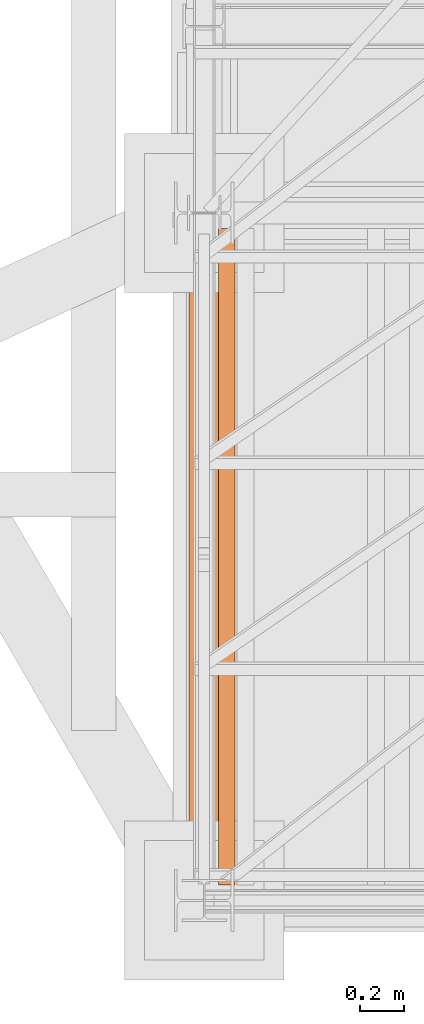
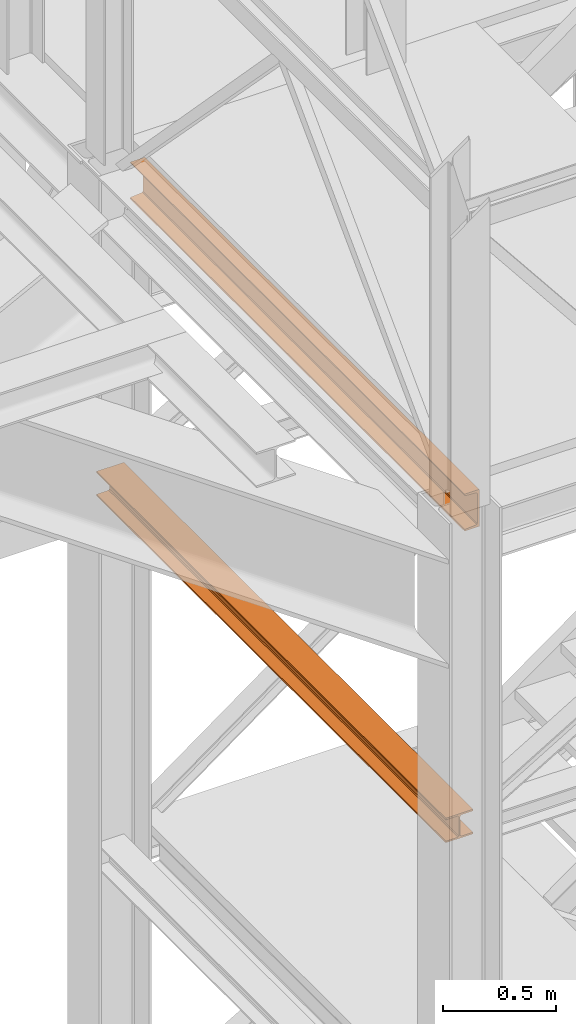
# One storey, part 4 of 208: 2 proxies.
"""IFC2X3 building model written with IfcOpenShell, lengths in millimetres."""

from ifc_helpers import new_model, entity, si_unit, converted_unit, frame, origin, origin_with_axes, place, context, subcontext, project, spatial, faceted_brep, element, save


model = new_model("IFC2X3")

# Units and contexts
model_context = context("Model", 3, precision=1e-05, world=origin())
plan_context = context("Plan", 3, precision=1e-05, world=origin())
body_context = subcontext(model_context, "Body", "Model", "MODEL_VIEW")
ifc_project = project(units=[si_unit("LENGTHUNIT", "METRE", prefix="MILLI"), converted_unit("PLANEANGLEUNIT", "DEGREE", entity("IfcPlaneAngleMeasure", 0.0174532925199433), si_unit("PLANEANGLEUNIT", "RADIAN"), dimensions=[0, 0, 0, 0, 0, 0, 0]), si_unit("AREAUNIT", "SQUARE_METRE"), si_unit("VOLUMEUNIT", "CUBIC_METRE")], contexts=[model_context, plan_context])

# Building, storey
building_placement = place(None, origin())
building = spatial("IfcBuilding", under=ifc_project, at=building_placement, CompositionType="COMPLEX")
storey_placement = place(building_placement, origin_with_axes())
storey = spatial("IfcBuildingStorey", under=building, at=storey_placement, Name="Geschoss", CompositionType="ELEMENT")

# Proxies
proxy_1_placement = place(storey_placement, frame((1128.922936086901, -25168.5743901279, 3447.489998909947), z_axis=(0.0, 0.0, 1.0), x_axis=(1.0, 0.0, 0.0)))
element("IfcBuildingElementProxy", 1, at=proxy_1_placement, inside=storey, context=body_context, shape_type="Brep", body=[
    faceted_brep([(0.01000000000067303, 3102.009999620019, 8.510002324581365), (0.01000000000067303, 3102.009999620019, 0.01000000000021828), (140.0100005960469, 3102.009999620019, 0.01000000000021828), (140.0100005960469, 3102.009999620019, 8.510002324581365), (84.76000038743086, 3102.009999620019, 8.510002324581365), (78.54945996612378, 3102.009999620019, 9.753034839630345), (74.00303279817172, 3102.009999620019, 14.29946480155013), (72.76000051595338, 3102.009999620019, 20.51000429153464), (72.76000051595338, 3102.009999620019, 112.5100007450583), (74.00303279817172, 3102.009999620019, 118.7205402350428), (78.54945996612378, 3102.009999620019, 123.2669664716723), (84.76000038743086, 3102.009999620019, 124.5099989867213), (140.0100005960469, 3102.009999620019, 124.5099989867213), (140.0100005960469, 3102.009999620019, 133.0100013113024), (0.01000000000067303, 3102.009999620019, 133.0100013113024), (0.01000000000067303, 3102.009999620019, 124.5099989867213), (55.26000020861693, 3102.009999620019, 124.5099989867213), (61.47054062992402, 3102.009999620019, 123.2669664716723), (66.01696779787608, 3102.009999620019, 118.7205402350428), (67.26000008009441, 3102.009999620019, 112.5100007450583), (67.26000008009441, 3102.009999620019, 20.51000429153464), (66.01696779787608, 3102.009999620019, 14.29946480155013), (61.47054062992402, 3102.009999620019, 9.753034839630345), (55.26000020861693, 3102.009999620019, 8.510002324581365), (0.01000000000067303, 3102.009999620019, 0.01000000000021828), (0.01000000000067303, 3102.009999620019, 8.510002324581365), (0.01000000000021828, 0.00999999999839929, 8.510002324581365), (0.01000000000021828, 0.00999999999839929, 0.01000000000021828), (140.0100005960469, 3102.009999620019, 0.01000000000021828), (0.01000000000067303, 3102.009999620019, 0.01000000000021828), (0.01000000000021828, 0.00999999999839929, 0.01000000000021828), (140.0100005960467, 0.00999999999839929, 0.01000000000021828), (140.0100005960469, 3102.009999620019, 8.510002324581365), (140.0100005960469, 3102.009999620019, 0.01000000000021828), (140.0100005960467, 0.00999999999839929, 0.01000000000021828), (140.0100005960467, 0.00999999999839929, 8.510002324581365), (84.76000038743086, 3102.009999620019, 8.510002324581365), (140.0100005960469, 3102.009999620019, 8.510002324581365), (140.0100005960467, 0.00999999999839929, 8.510002324581365), (84.76000038743041, 0.00999999999839929, 8.510002324581365), (78.54945996612378, 3102.009999620019, 9.753034839630345), (84.76000038743086, 3102.009999620019, 8.510002324581365), (84.76000038743041, 0.00999999999839929, 8.510002324581365), (78.54945996612332, 0.00999999999839929, 9.753034839630345), (74.00303279817172, 3102.009999620019, 14.29946480155013), (78.54945996612378, 3102.009999620019, 9.753034839630345), (78.54945996612332, 0.00999999999839929, 9.753034839630345), (74.00303279817126, 0.00999999999839929, 14.29946480155013), (72.76000051595338, 3102.009999620019, 20.51000429153464), (74.00303279817172, 3102.009999620019, 14.29946480155013), (74.00303279817126, 0.00999999999839929, 14.29946480155013), (72.76000051595292, 0.00999999999839929, 20.51000429153464), (72.76000051595338, 3102.009999620019, 112.5100007450583), (72.76000051595338, 3102.009999620019, 20.51000429153464), (72.76000051595292, 0.00999999999839929, 20.51000429153464), (72.76000051595292, 0.00999999999839929, 112.5100007450583), (74.00303279817172, 3102.009999620019, 118.7205402350428), (72.76000051595338, 3102.009999620019, 112.5100007450583), (72.76000051595292, 0.00999999999839929, 112.5100007450583), (74.00303279817126, 0.00999999999839929, 118.7205402350428), (78.54945996612378, 3102.009999620019, 123.2669664716723), (74.00303279817172, 3102.009999620019, 118.7205402350428), (74.00303279817126, 0.00999999999839929, 118.7205402350428), (78.54945996612332, 0.00999999999839929, 123.2669664716723), (84.76000038743086, 3102.009999620019, 124.5099989867213), (78.54945996612378, 3102.009999620019, 123.2669664716723), (78.54945996612332, 0.00999999999839929, 123.2669664716723), (84.76000038743041, 0.00999999999839929, 124.5099989867213), (140.0100005960469, 3102.009999620019, 124.5099989867213), (84.76000038743086, 3102.009999620019, 124.5099989867213), (84.76000038743041, 0.00999999999839929, 124.5099989867213), (140.0100005960467, 0.00999999999839929, 124.5099989867213), (140.0100005960469, 3102.009999620019, 133.0100013113024), (140.0100005960469, 3102.009999620019, 124.5099989867213), (140.0100005960467, 0.00999999999839929, 124.5099989867213), (140.0100005960467, 0.00999999999839929, 133.0100013113024), (0.01000000000067303, 3102.009999620019, 133.0100013113024), (140.0100005960469, 3102.009999620019, 133.0100013113024), (140.0100005960467, 0.00999999999839929, 133.0100013113024), (0.01000000000021828, 0.00999999999839929, 133.0100013113024), (0.01000000000067303, 3102.009999620019, 124.5099989867213), (0.01000000000067303, 3102.009999620019, 133.0100013113024), (0.01000000000021828, 0.00999999999839929, 133.0100013113024), (0.01000000000021828, 0.00999999999839929, 124.5099989867213), (55.26000020861693, 3102.009999620019, 124.5099989867213), (0.01000000000067303, 3102.009999620019, 124.5099989867213), (0.01000000000021828, 0.00999999999839929, 124.5099989867213), (55.26000020861648, 0.00999999999839929, 124.5099989867213), (61.47054062992402, 3102.009999620019, 123.2669664716723), (55.26000020861693, 3102.009999620019, 124.5099989867213), (55.26000020861648, 0.00999999999839929, 124.5099989867213), (61.47054062992356, 0.00999999999839929, 123.2669664716723), (66.01696779787608, 3102.009999620019, 118.7205402350428), (61.47054062992402, 3102.009999620019, 123.2669664716723), (61.47054062992356, 0.00999999999839929, 123.2669664716723), (66.01696779787562, 0.00999999999839929, 118.7205402350428), (67.26000008009441, 3102.009999620019, 112.5100007450583), (66.01696779787608, 3102.009999620019, 118.7205402350428), (66.01696779787562, 0.00999999999839929, 118.7205402350428), (67.26000008009396, 0.00999999999839929, 112.5100007450583), (67.26000008009441, 3102.009999620019, 20.51000429153464), (67.26000008009441, 3102.009999620019, 112.5100007450583), (67.26000008009396, 0.00999999999839929, 112.5100007450583), (67.26000008009396, 0.00999999999839929, 20.51000429153464), (66.01696779787608, 3102.009999620019, 14.29946480155013), (67.26000008009441, 3102.009999620019, 20.51000429153464), (67.26000008009396, 0.00999999999839929, 20.51000429153464), (66.01696779787562, 0.00999999999839929, 14.29946480155013), (61.47054062992402, 3102.009999620019, 9.753034839630345), (66.01696779787608, 3102.009999620019, 14.29946480155013), (66.01696779787562, 0.00999999999839929, 14.29946480155013), (61.47054062992356, 0.00999999999839929, 9.753034839630345), (55.26000020861693, 3102.009999620019, 8.510002324581365), (61.47054062992402, 3102.009999620019, 9.753034839630345), (61.47054062992356, 0.00999999999839929, 9.753034839630345), (55.26000020861648, 0.00999999999839929, 8.510002324581365), (0.01000000000067303, 3102.009999620019, 8.510002324581365), (55.26000020861693, 3102.009999620019, 8.510002324581365), (55.26000020861648, 0.00999999999839929, 8.510002324581365), (0.01000000000021828, 0.00999999999839929, 8.510002324581365), (0.01000000000021828, 0.00999999999839929, 8.510002324581365), (55.26000020861648, 0.00999999999839929, 8.510002324581365), (61.47054062992356, 0.00999999999839929, 9.753034839630345), (66.01696779787562, 0.00999999999839929, 14.29946480155013), (67.26000008009396, 0.00999999999839929, 20.51000429153464), (67.26000008009396, 0.00999999999839929, 112.5100007450583), (66.01696779787562, 0.00999999999839929, 118.7205402350428), (61.47054062992356, 0.00999999999839929, 123.2669664716723), (55.26000020861648, 0.00999999999839929, 124.5099989867213), (0.01000000000021828, 0.00999999999839929, 124.5099989867213), (0.01000000000021828, 0.00999999999839929, 133.0100013113024), (140.0100005960467, 0.00999999999839929, 133.0100013113024), (140.0100005960467, 0.00999999999839929, 124.5099989867213), (84.76000038743041, 0.00999999999839929, 124.5099989867213), (78.54945996612332, 0.00999999999839929, 123.2669664716723), (74.00303279817126, 0.00999999999839929, 118.7205402350428), (72.76000051595292, 0.00999999999839929, 112.5100007450583), (72.76000051595292, 0.00999999999839929, 20.51000429153464), (74.00303279817126, 0.00999999999839929, 14.29946480155013), (78.54945996612332, 0.00999999999839929, 9.753034839630345), (84.76000038743041, 0.00999999999839929, 8.510002324581365), (140.0100005960467, 0.00999999999839929, 8.510002324581365), (140.0100005960467, 0.00999999999839929, 0.01000000000021828), (0.01000000000021828, 0.00999999999839929, 0.01000000000021828)], [[[0, 1, 2, 3, 4, 5, 6, 7, 8, 9, 10, 11, 12, 13, 14, 15, 16, 17, 18, 19, 20, 21, 22, 23]], [[24, 25, 26, 27]], [[28, 29, 30, 31]], [[32, 33, 34, 35]], [[36, 37, 38, 39]], [[40, 41, 42, 43]], [[44, 45, 46, 47]], [[48, 49, 50, 51]], [[52, 53, 54, 55]], [[56, 57, 58, 59]], [[60, 61, 62, 63]], [[64, 65, 66, 67]], [[68, 69, 70, 71]], [[72, 73, 74, 75]], [[76, 77, 78, 79]], [[80, 81, 82, 83]], [[84, 85, 86, 87]], [[88, 89, 90, 91]], [[92, 93, 94, 95]], [[96, 97, 98, 99]], [[100, 101, 102, 103]], [[104, 105, 106, 107]], [[108, 109, 110, 111]], [[112, 113, 114, 115]], [[116, 117, 118, 119]], [[120, 121, 122, 123, 124, 125, 126, 127, 128, 129, 130, 131, 132, 133, 134, 135, 136, 137, 138, 139, 140, 141, 142, 143]]], orient=[[False], [False], [False], [False], [False], [False], [False], [False], [False], [False], [False], [False], [False], [False], [False], [False], [False], [False], [False], [False], [False], [False], [False], [False], [False], [False]]),
])
proxy_2_placement = place(storey_placement, frame((1263.401408260117, -25102.57439001986, 5049.989998509882), z_axis=(0.0, 0.0, 1.0), x_axis=(1.0, 0.0, 0.0)))
element("IfcBuildingElementProxy", 2, at=proxy_2_placement, inside=storey, context=body_context, shape_type="Brep", body=[
    faceted_brep([(75.01000111758754, 2970.009999403952, 200.0100029802325), (0.01000000000044565, 2970.009999403952, 200.0100029802325), (0.01000000000044565, 2970.009999403952, 197.0491720533373), (1.126000115871875, 2970.009999403952, 192.6511688327792), (5.531528422832935, 2970.009999403952, 191.0682780838015), (55.92706931591079, 2970.009999403952, 187.0366348123553), (61.66620032697961, 2970.009999403952, 185.4414133524897), (65.51985109061047, 2970.009999403952, 181.1611144042017), (66.51000065565154, 2970.009999403952, 175.5732609128954), (66.51000065565154, 2970.009999403952, 24.44674206733725), (65.51985109061047, 2970.009999403952, 18.85888857603095), (61.66620032697961, 2970.009999403952, 14.57858962774299), (55.92706931591079, 2970.009999403952, 12.98336816787742), (5.531528422832935, 2970.009999403952, 8.951724896431188), (1.126000115871875, 2970.009999403952, 7.368834147453526), (0.01000000000044565, 2970.009999403952, 2.97083092689536), (0.01000000000044565, 2970.009999403952, 0.01000000000021828), (75.01000111758754, 2970.009999403952, 0.01000000000021828), (75.01000111758754, 2970.009999403952, 0.01000000000021828), (75.01000111758708, 0.00999999999839929, 0.01000000000021828), (75.01000111758708, 0.00999999999839929, 200.0100029802325), (75.01000111758754, 2970.009999403952, 200.0100029802325), (0.01000000000044565, 2970.009999403952, 0.01000000000021828), (0.009999999999990905, 0.00999999999839929, 0.01000000000021828), (75.01000111758708, 0.00999999999839929, 0.01000000000021828), (75.01000111758754, 2970.009999403952, 0.01000000000021828), (0.01000000000044565, 2970.009999403952, 2.97083092689536), (0.009999999999990905, 0.00999999999839929, 2.97083092689536), (0.009999999999990905, 0.00999999999839929, 0.01000000000021828), (0.01000000000044565, 2970.009999403952, 0.01000000000021828), (1.126000115871875, 2970.009999403952, 7.368834147453526), (1.12600011587142, 0.00999999999839929, 7.368834147453526), (0.009999999999990905, 0.00999999999839929, 2.97083092689536), (0.01000000000044565, 2970.009999403952, 2.97083092689536), (5.531528422832935, 2970.009999403952, 8.951724896431188), (5.53152842283248, 0.00999999999839929, 8.951724896431188), (1.12600011587142, 0.00999999999839929, 7.368834147453526), (1.126000115871875, 2970.009999403952, 7.368834147453526), (55.92706931591079, 2970.009999403952, 12.98336816787742), (55.92706931591033, 0.00999999999839929, 12.98336816787742), (5.53152842283248, 0.00999999999839929, 8.951724896431188), (5.531528422832935, 2970.009999403952, 8.951724896431188), (61.66620032697961, 2970.009999403952, 14.57858962774299), (61.66620032697915, 0.00999999999839929, 14.57858962774299), (55.92706931591033, 0.00999999999839929, 12.98336816787742), (55.92706931591079, 2970.009999403952, 12.98336816787742), (65.51985109061047, 2970.009999403952, 18.85888857603095), (65.51985109061002, 0.00999999999839929, 18.85888857603095), (61.66620032697915, 0.00999999999839929, 14.57858962774299), (61.66620032697961, 2970.009999403952, 14.57858962774299), (66.51000065565154, 2970.009999403952, 24.44674206733725), (66.51000065565108, 0.00999999999839929, 24.44674206733725), (65.51985109061002, 0.00999999999839929, 18.85888857603095), (65.51985109061047, 2970.009999403952, 18.85888857603095), (66.51000065565154, 2970.009999403952, 175.5732609128954), (66.51000065565108, 0.00999999999839929, 175.5732609128954), (66.51000065565108, 0.00999999999839929, 24.44674206733725), (66.51000065565154, 2970.009999403952, 24.44674206733725), (65.51985109061047, 2970.009999403952, 181.1611144042017), (65.51985109061002, 0.00999999999839929, 181.1611144042017), (66.51000065565108, 0.00999999999839929, 175.5732609128954), (66.51000065565154, 2970.009999403952, 175.5732609128954), (61.66620032697961, 2970.009999403952, 185.4414133524897), (61.66620032697915, 0.00999999999839929, 185.4414133524897), (65.51985109061002, 0.00999999999839929, 181.1611144042017), (65.51985109061047, 2970.009999403952, 181.1611144042017), (55.92706931591079, 2970.009999403952, 187.0366348123553), (55.92706931591033, 0.00999999999839929, 187.0366348123553), (61.66620032697915, 0.00999999999839929, 185.4414133524897), (61.66620032697961, 2970.009999403952, 185.4414133524897), (5.531528422832935, 2970.009999403952, 191.0682780838015), (5.53152842283248, 0.00999999999839929, 191.0682780838015), (55.92706931591033, 0.00999999999839929, 187.0366348123553), (55.92706931591079, 2970.009999403952, 187.0366348123553), (1.126000115871875, 2970.009999403952, 192.6511688327792), (1.12600011587142, 0.00999999999839929, 192.6511688327792), (5.53152842283248, 0.00999999999839929, 191.0682780838015), (5.531528422832935, 2970.009999403952, 191.0682780838015), (0.01000000000044565, 2970.009999403952, 197.0491720533373), (0.009999999999990905, 0.00999999999839929, 197.0491720533373), (1.12600011587142, 0.00999999999839929, 192.6511688327792), (1.126000115871875, 2970.009999403952, 192.6511688327792), (0.01000000000044565, 2970.009999403952, 200.0100029802325), (0.009999999999990905, 0.00999999999839929, 200.0100029802325), (0.009999999999990905, 0.00999999999839929, 197.0491720533373), (0.01000000000044565, 2970.009999403952, 197.0491720533373), (75.01000111758754, 2970.009999403952, 200.0100029802325), (75.01000111758708, 0.00999999999839929, 200.0100029802325), (0.009999999999990905, 0.00999999999839929, 200.0100029802325), (0.01000000000044565, 2970.009999403952, 200.0100029802325), (75.01000111758708, 0.00999999999839929, 200.0100029802325), (75.01000111758708, 0.00999999999839929, 0.01000000000021828), (0.009999999999990905, 0.00999999999839929, 0.01000000000021828), (0.009999999999990905, 0.00999999999839929, 2.97083092689536), (1.12600011587142, 0.00999999999839929, 7.368834147453526), (5.53152842283248, 0.00999999999839929, 8.951724896431188), (55.92706931591033, 0.00999999999839929, 12.98336816787742), (61.66620032697915, 0.00999999999839929, 14.57858962774299), (65.51985109061002, 0.00999999999839929, 18.85888857603095), (66.51000065565108, 0.00999999999839929, 24.44674206733725), (66.51000065565108, 0.00999999999839929, 175.5732609128954), (65.51985109061002, 0.00999999999839929, 181.1611144042017), (61.66620032697915, 0.00999999999839929, 185.4414133524897), (55.92706931591033, 0.00999999999839929, 187.0366348123553), (5.53152842283248, 0.00999999999839929, 191.0682780838015), (1.12600011587142, 0.00999999999839929, 192.6511688327792), (0.009999999999990905, 0.00999999999839929, 197.0491720533373), (0.009999999999990905, 0.00999999999839929, 200.0100029802325)], [[[0, 1, 2, 3, 4, 5, 6, 7, 8, 9, 10, 11, 12, 13, 14, 15, 16, 17]], [[18, 19, 20, 21]], [[22, 23, 24, 25]], [[26, 27, 28, 29]], [[30, 31, 32, 33]], [[34, 35, 36, 37]], [[38, 39, 40, 41]], [[42, 43, 44, 45]], [[46, 47, 48, 49]], [[50, 51, 52, 53]], [[54, 55, 56, 57]], [[58, 59, 60, 61]], [[62, 63, 64, 65]], [[66, 67, 68, 69]], [[70, 71, 72, 73]], [[74, 75, 76, 77]], [[78, 79, 80, 81]], [[82, 83, 84, 85]], [[86, 87, 88, 89]], [[90, 91, 92, 93, 94, 95, 96, 97, 98, 99, 100, 101, 102, 103, 104, 105, 106, 107]]], orient=[[False], [False], [False], [False], [False], [False], [False], [False], [False], [False], [False], [False], [False], [False], [False], [False], [False], [False], [False], [False]]),
])

save(model, "model.ifc")
